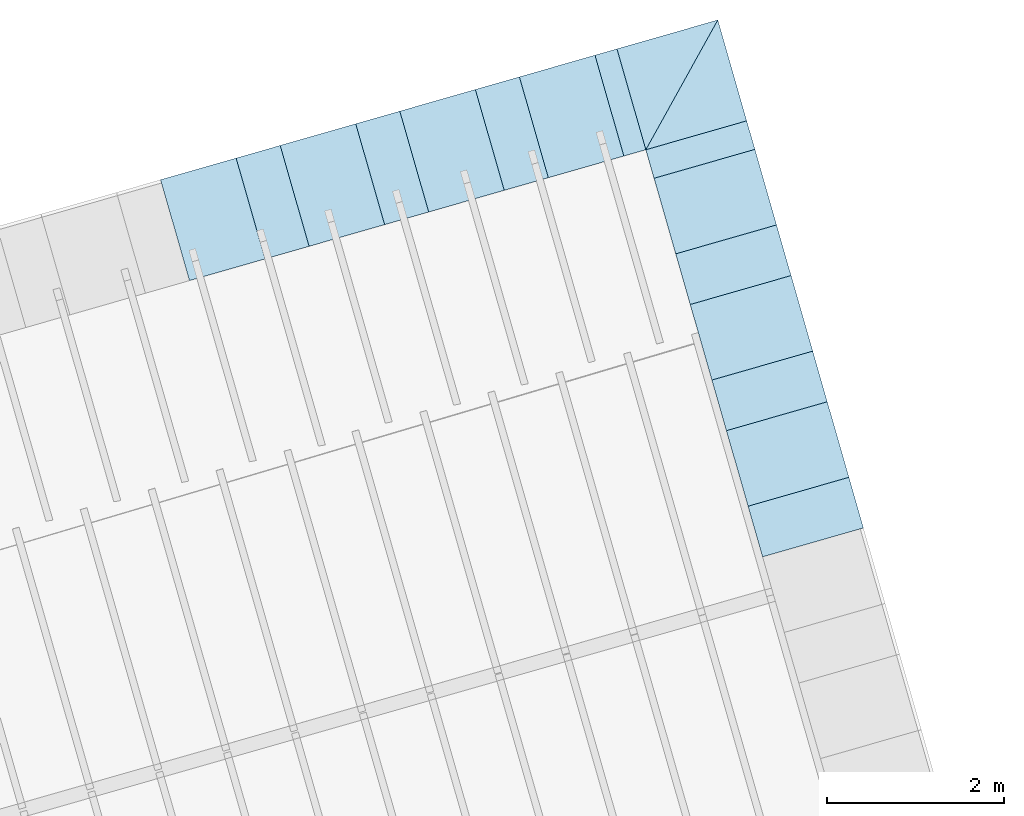
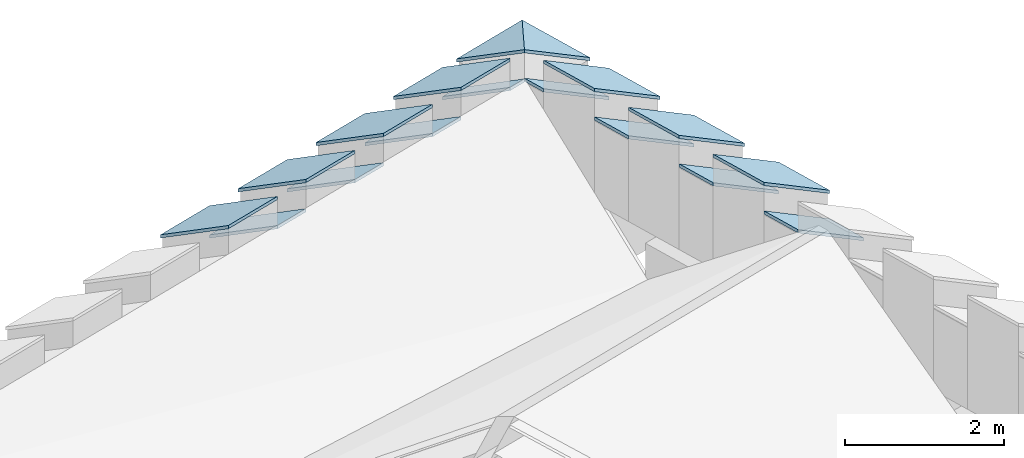
# One storey, part 4 of 10: 17 roofs.
"""IFC4 building model written with IfcOpenShell, lengths in metres."""

from ifc_helpers import new_model, entity, si_unit, converted_unit, derived_unit, direction, frame, origin_with_axes, place, context, subcontext, project, spatial, polygons, material, type_object, element, save


model = new_model("IFC4")

# Units and contexts
model_context = context("Model", 3, precision=1e-05, world=origin_with_axes(), true_north=direction((0.0, 1.0)))
body_context = subcontext(model_context, "Body", "Model", "MODEL_VIEW")
ifc_project = project(units=[si_unit("LENGTHUNIT", "METRE"), si_unit("AREAUNIT", "SQUARE_METRE"), si_unit("VOLUMEUNIT", "CUBIC_METRE"), converted_unit("PLANEANGLEUNIT", "DEGREE", entity("IfcPlaneAngleMeasure", 0.0174532925199433), si_unit("PLANEANGLEUNIT", "RADIAN"), dimensions=[0, 0, 0, 0, 0, 0, 0]), converted_unit("TIMEUNIT", "Year", entity("IfcTimeMeasure", 31557600.0), si_unit("TIMEUNIT", "SECOND"), dimensions=[0, 0, 1, 0, 0, 0, 0]), si_unit("MASSUNIT", "GRAM", prefix="KILO"), si_unit("THERMODYNAMICTEMPERATUREUNIT", "DEGREE_CELSIUS"), si_unit("LUMINOUSINTENSITYUNIT", "LUMEN"), si_unit("ENERGYUNIT", "JOULE", prefix="MEGA"), derived_unit("THERMALCONDUCTANCEUNIT", [(si_unit("POWERUNIT", "WATT"), 1), (si_unit("LENGTHUNIT", "METRE"), -1), (si_unit("THERMODYNAMICTEMPERATUREUNIT", "KELVIN"), -1)]), derived_unit("SPECIFICHEATCAPACITYUNIT", [(si_unit("ENERGYUNIT", "JOULE"), 1), (si_unit("MASSUNIT", "GRAM", prefix="KILO"), -1), (si_unit("THERMODYNAMICTEMPERATUREUNIT", "KELVIN"), -1)]), derived_unit("MASSDENSITYUNIT", [(si_unit("MASSUNIT", "GRAM", prefix="KILO"), 1), (si_unit("VOLUMEUNIT", "CUBIC_METRE"), -1)])], contexts=[model_context])

# Site, building, storey
site_placement = place(None, frame((0.0, 0.0, 0.0), z_axis=(0.0, 0.0, 1.0), x_axis=(0.9612616959383189, 0.2756373558169991, 0.0)))
site = spatial("IfcSite", under=ifc_project, at=site_placement, CompositionType="ELEMENT")
building_placement = place(site_placement, origin_with_axes())
building = spatial("IfcBuilding", under=site, at=building_placement, CompositionType="ELEMENT")
storey_placement = place(building_placement, frame((0.0, 0.0, 11.0), z_axis=(0.0, 0.0, 1.0), x_axis=(1.0, 0.0, 0.0)))
storey = spatial("IfcBuildingStorey", under=building, at=storey_placement, Name="Dach", CompositionType="ELEMENT", Elevation=11.0)

# Roofs
ifc_material = material(Name="schwarz")
roof_type = type_object("IfcRoofType", Name="schwarz 43", PredefinedType="NOTDEFINED")
roof_1_placement = place(storey_placement, frame((31.60143138456926, 13.95742781004919, 1.213699999999999), z_axis=(0.0, 0.0, 1.0), x_axis=(0.0, 1.0, 0.0)))
element("IfcRoof", 1, at=roof_1_placement, inside=storey, type_object=roof_type, material=ifc_material, Name="Dach-060", PredefinedType="NOTDEFINED", context=body_context, shape_type="Tessellation", body=[
    polygons([(0.8900025616952458, -0.03772698703641097, 0.02714466037988217), (0.8900025616952494, 1.149999999999988, 0.7466800857374238), (0.0, 1.149999999999991, 0.7466800857374274), (0.0, -0.03772698703641097, 0.02714466037988217), (0.8900025620847654, -0.03772698691103571, -0.02285533967409492), (0.8900025620847671, 1.150000000333105, 0.6966800858093016), (3.51640494500316e-10, 1.150000000333105, 0.6966800858093016), (3.516387181434766e-10, -0.03772698691103571, -0.02285533967409492)], [[[1, 2, 3, 4]], [[2, 1, 5, 6]], [[3, 2, 6, 7]], [[4, 3, 7, 8]], [[1, 4, 8, 5]], [[6, 5, 8, 7]]], closed=True),
])
roof_2_placement = place(storey_placement, frame((31.60143138441791, 15.4438330749515, 1.213699999999999), z_axis=(0.0, 0.0, 1.0), x_axis=(0.0, 1.0, 0.0)))
element("IfcRoof", 2, at=roof_2_placement, inside=storey, type_object=roof_type, material=ifc_material, Name="Dach-060", PredefinedType="NOTDEFINED", context=body_context, shape_type="Tessellation", body=[
    polygons([(0.8900025616952458, -0.03772698703640742, 0.02714466037987862), (0.8900025616952458, 1.149999999999988, 0.7466800857374238), (0.0, 1.149999999999995, 0.7466800857374274), (0.0, -0.03772698703640742, 0.02714466037987862), (0.8900025620847654, -0.03772698691103571, -0.02285533967409847), (0.8900025620847618, 1.150000000333108, 0.6966800858092981), (3.516369417866372e-10, 1.150000000333108, 0.6966800858092981), (3.516351654297978e-10, -0.03772698691103571, -0.02285533967409847)], [[[1, 2, 3, 4]], [[2, 1, 5, 6]], [[3, 2, 6, 7]], [[4, 3, 7, 8]], [[1, 4, 8, 5]], [[6, 5, 8, 7]]], closed=True),
])
roof_3_placement = place(storey_placement, frame((31.60143138462978, 13.95742672876634, 0.7745999999999995), z_axis=(0.0, 0.0, 1.0), x_axis=(0.0, -1.0, 0.0)))
element("IfcRoof", 3, at=roof_3_placement, inside=storey, type_object=roof_type, material=ifc_material, Name="Dach-059", PredefinedType="NOTDEFINED", context=body_context, shape_type="Tessellation", body=[
    polygons([(0.0, -1.149999999999999, 0.7466800857374274), (0.5964000000000027, -1.149999999999991, 0.7466800857374238), (0.5963999999999992, 0.03772698703645005, 0.02714466037985375), (0.0, 0.03772698703645005, 0.02714466037985375), (-3.895159750300081e-10, -1.150000000333108, 0.6966800858093016), (0.5963999997654561, -1.150000000333108, 0.6966800858093016), (0.5963999997654561, 0.03772698691103216, -0.02285533967409847), (-3.895159750300081e-10, 0.03772698691103216, -0.02285533967409847)], [[[1, 2, 3, 4]], [[2, 1, 5, 6]], [[3, 2, 6, 7]], [[4, 3, 7, 8]], [[1, 4, 8, 5]], [[6, 5, 8, 7]]], closed=True),
])
roof_4_placement = place(storey_placement, frame((31.60143138444817, 15.44383253431008, 0.7745999999999995), z_axis=(0.0, 0.0, 1.0), x_axis=(0.0, -1.0, 0.0)))
element("IfcRoof", 4, at=roof_4_placement, inside=storey, type_object=roof_type, material=ifc_material, Name="Dach-059", PredefinedType="NOTDEFINED", context=body_context, shape_type="Tessellation", body=[
    polygons([(0.0, -1.149999999999995, 0.7466800857374274), (0.5964000000000027, -1.149999999999988, 0.7466800857374238), (0.5963999999999992, 0.03772698703645361, 0.02714466037985375), (0.0, 0.03772698703645361, 0.02714466037985375), (-3.895159750300081e-10, -1.150000000333105, 0.6966800858093016), (0.5963999997654561, -1.150000000333105, 0.6966800858093016), (0.5963999997654561, 0.03772698691103571, -0.02285533967409492), (-3.895159750300081e-10, 0.03772698691103571, -0.02285533967409492)], [[[1, 2, 3, 4]], [[2, 1, 5, 6]], [[3, 2, 6, 7]], [[4, 3, 7, 8]], [[1, 4, 8, 5]], [[6, 5, 8, 7]]], closed=True),
])
roof_5_placement = place(storey_placement, frame((31.60143138426657, 16.93023833985382, 0.7745999999999995), z_axis=(0.0, 0.0, 1.0), x_axis=(0.0, -1.0, 0.0)))
element("IfcRoof", 5, at=roof_5_placement, inside=storey, type_object=roof_type, material=ifc_material, Name="Dach-059", PredefinedType="NOTDEFINED", context=body_context, shape_type="Tessellation", body=[
    polygons([(0.0, -1.149999999999999, 0.7466800857374309), (0.5964000000000027, -1.149999999999988, 0.7466800857374238), (0.5963999999999956, 0.03772698703645361, 0.02714466037985019), (0.0, 0.03772698703645361, 0.02714466037985019), (-3.895159750300081e-10, -1.150000000333112, 0.6966800858093016), (0.5963999997654561, -1.150000000333112, 0.6966800858093016), (0.5963999997654561, 0.0377269869110286, -0.02285533967409492), (-3.895159750300081e-10, 0.0377269869110286, -0.02285533967409492)], [[[1, 2, 3, 4]], [[2, 1, 5, 6]], [[3, 2, 6, 7]], [[4, 3, 7, 8]], [[1, 4, 8, 5]], [[6, 5, 8, 7]]], closed=True),
])
roof_6_placement = place(storey_placement, frame((31.60143139039683, 18.15664638990928, 0.7745999999999995), z_axis=(0.0, 0.0, 1.0), x_axis=(0.0, -1.0, 0.0)))
element("IfcRoof", 6, at=roof_6_placement, inside=storey, type_object=roof_type, material=ifc_material, Name="Dach-058", PredefinedType="NOTDEFINED", context=body_context, shape_type="Tessellation", body=[
    polygons([(-7.37155403385259e-09, 0.03772698688035447, 0.02714466032906415), (2.247008623612601e-07, -1.14999999652429, 0.7466800945752929), (0.3364054846060398, -1.149999993345968, 0.7466800926498394), (0.3364054841255495, 0.03772698688035447, 0.02714466032906415), (-1.210476341384492e-08, 0.03772698706562139, -0.02285534011997115), (2.207258802400247e-07, -1.149999996857442, 0.6966800944403211), (0.3364054846092657, -1.149999993671226, 0.696680092510082), (0.3364054836779431, 0.03772698706562139, -0.02285534011997115)], [[[1, 2, 3, 4]], [[2, 1, 5, 6]], [[3, 2, 6, 7]], [[4, 3, 7, 8]], [[1, 4, 8, 5]], [[6, 5, 8, 7]]], closed=True),
])
roof_7_placement = place(storey_placement, frame((31.60143138426657, 16.93023833985382, 1.213699999999999), z_axis=(0.0, 0.0, 1.0), x_axis=(0.0, 1.0, 0.0)))
element("IfcRoof", 7, at=roof_7_placement, inside=storey, type_object=roof_type, material=ifc_material, Name="Dach-060", PredefinedType="NOTDEFINED", context=body_context, shape_type="Tessellation", body=[
    polygons([(0.8900025616952476, -0.03772698703641097, 0.02714466037987862), (0.8900025616952476, 1.149999999999988, 0.7466800857374238), (0.0, 1.149999999999995, 0.7466800857374274), (0.0, -0.03772698703641097, 0.02714466037987862), (0.8900025620847671, -0.03772698691103571, -0.02285533967409492), (0.8900025620847636, 1.150000000333108, 0.6966800858093016), (3.516369417866372e-10, 1.150000000333108, 0.6966800858093016), (3.51640494500316e-10, -0.03772698691103571, -0.02285533967409492)], [[[1, 2, 3, 4]], [[2, 1, 5, 6]], [[3, 2, 6, 7]], [[4, 3, 7, 8]], [[1, 4, 8, 5]], [[6, 5, 8, 7]]], closed=True),
])
roof_8_placement = place(storey_placement, frame((25.96558752642708, 19.30664615507484, 1.213699999999999), z_axis=(0.0, 0.0, 1.0), x_axis=(-1.0, 0.0, 0.0)))
element("IfcRoof", 8, at=roof_8_placement, inside=storey, type_object=roof_type, material=ifc_material, Name="Dach-057", PredefinedType="NOTDEFINED", context=body_context, shape_type="Tessellation", body=[
    polygons([(0.8900025616952547, -0.0377269870364465, 0.0271446603798573), (0.8900025616952547, 1.149999999999995, 0.7466800857374327), (0.0, 1.149999999999995, 0.7466800857374327), (0.0, -0.0377269870364465, 0.0271446603798573), (0.8900025620847707, -0.03772698691103926, -0.02285533967409847), (0.8900025620847707, 1.150000000333101, 0.6966800858093016), (3.516440472139948e-10, 1.150000000333101, 0.6966800858093016), (3.516440472139948e-10, -0.03772698691103926, -0.02285533967409847)], [[[1, 2, 3, 4]], [[2, 1, 5, 6]], [[3, 2, 6, 7]], [[4, 3, 7, 8]], [[1, 4, 8, 5]], [[6, 5, 8, 7]]], closed=True),
])
roof_9_placement = place(storey_placement, frame((27.37454827656133, 19.3066461584527, 1.213699999999999), z_axis=(0.0, 0.0, 1.0), x_axis=(-1.0, 0.0, 0.0)))
element("IfcRoof", 9, at=roof_9_placement, inside=storey, type_object=roof_type, material=ifc_material, Name="Dach-057", PredefinedType="NOTDEFINED", context=body_context, shape_type="Tessellation", body=[
    polygons([(0.8900025616952547, -0.0377269870364465, 0.02714466037985552), (0.8900025616952547, 1.149999999999999, 0.7466800857374327), (0.0, 1.149999999999999, 0.7466800857374327), (0.0, -0.0377269870364465, 0.02714466037985552), (0.8900025620847707, -0.03772698691103571, -0.02285533967409847), (0.8900025620847707, 1.150000000333101, 0.6966800858093016), (3.516440472139948e-10, 1.150000000333101, 0.6966800858093016), (3.516440472139948e-10, -0.03772698691103571, -0.02285533967409847)], [[[1, 2, 3, 4]], [[2, 1, 5, 6]], [[3, 2, 6, 7]], [[4, 3, 7, 8]], [[1, 4, 8, 5]], [[6, 5, 8, 7]]], closed=True),
])
roof_10_placement = place(storey_placement, frame((28.7835090266956, 19.30664616183056, 1.213699999999999), z_axis=(0.0, 0.0, 1.0), x_axis=(-1.0, 0.0, 0.0)))
element("IfcRoof", 10, at=roof_10_placement, inside=storey, type_object=roof_type, material=ifc_material, Name="Dach-057", PredefinedType="NOTDEFINED", context=body_context, shape_type="Tessellation", body=[
    polygons([(0.8900025616952547, -0.03772698703645005, 0.02714466037985197), (0.8900025616952547, 1.149999999999999, 0.7466800857374327), (0.0, 1.149999999999999, 0.7466800857374327), (0.0, -0.03772698703644295, 0.0271446603798573), (0.8900025620847707, -0.03772698691103571, -0.02285533967409847), (0.8900025620847707, 1.150000000333105, 0.6966800858093034), (3.516440472139948e-10, 1.150000000333105, 0.6966800858093034), (3.516440472139948e-10, -0.03772698691103571, -0.02285533967409847)], [[[1, 2, 3, 4]], [[2, 1, 5, 6]], [[3, 2, 6, 7]], [[4, 3, 7, 8]], [[1, 4, 8, 5]], [[6, 5, 8, 7]]], closed=True),
])
roof_11_placement = place(storey_placement, frame((30.19246977682985, 19.30664616520842, 1.213699999999999), z_axis=(0.0, 0.0, 1.0), x_axis=(-1.0, 0.0, 0.0)))
element("IfcRoof", 11, at=roof_11_placement, inside=storey, type_object=roof_type, material=ifc_material, Name="Dach-057", PredefinedType="NOTDEFINED", context=body_context, shape_type="Tessellation", body=[
    polygons([(0.8900025616952547, -0.03772698703645005, 0.02714466037985197), (0.8900025616952547, 1.149999999999999, 0.7466800857374309), (0.0, 1.149999999999999, 0.7466800857374309), (0.0, -0.03772698703644295, 0.02714466037985552), (0.8900025620847707, -0.03772698691103216, -0.02285533967409847), (0.8900025620847707, 1.150000000333105, 0.6966800858093016), (3.516440472139948e-10, 1.150000000333105, 0.6966800858093016), (3.516440472139948e-10, -0.03772698691103216, -0.02285533967409847)], [[[1, 2, 3, 4]], [[2, 1, 5, 6]], [[3, 2, 6, 7]], [[4, 3, 7, 8]], [[1, 4, 8, 5]], [[6, 5, 8, 7]]], closed=True),
])
roof_12_placement = place(storey_placement, frame((30.45143138835296, 19.30664616645134, 1.213699411030737), z_axis=(0.0, 0.0, 1.0), x_axis=(1.0, 0.0, 0.0)))
element("IfcRoof", 12, at=roof_12_placement, inside=storey, type_object=roof_type, material=ifc_material, Name="Dach-052", PredefinedType="NOTDEFINED", context=body_context, shape_type="Tessellation", body=[
    polygons([(-1.026982943130861e-10, 0.03772756924567844, 0.02714484985551557), (3.130345760382625e-09, -1.150000000000002, 0.7466392679194129), (1.187727569143259, 0.03772756924572107, 0.02714484985548893), (-5.617089016141108e-10, 0.03772756941491906, -0.02285437878040675), (3.163581396847803e-09, -1.150000000395778, 0.6966400396257644), (1.187727569103348, 0.03772756941491906, -0.02285437878040675)], [[[1, 2, 3]], [[2, 1, 4, 5]], [[3, 2, 5, 6]], [[1, 3, 6, 4]], [[5, 4, 6]]], closed=True),
])
roof_13_placement = place(storey_placement, frame((31.601431388353, 18.15664616645138, 1.213699411030737), z_axis=(0.0, 0.0, 1.0), x_axis=(0.0, 1.0, 0.0)))
element("IfcRoof", 13, at=roof_13_placement, inside=storey, type_object=roof_type, material=ifc_material, Name="Dach-051", PredefinedType="NOTDEFINED", context=body_context, shape_type="Tessellation", body=[
    polygons([(1.187727569245936, -0.0377275691432466, 0.02714484989189181), (-1.990088094316889e-10, 1.149999997068683, 0.7466392680765228), (-1.990372311411193e-10, -0.03772756914321818, 0.02714484989190957), (1.187727569634127, -0.03772756908859165, -0.02285437864493112), (0.0, 1.149999997400538, 0.6966400397076189), (0.0, -0.03772756908859165, -0.02285437864493112)], [[[1, 2, 3]], [[2, 1, 4, 5]], [[3, 2, 5, 6]], [[1, 3, 6, 4]], [[5, 4, 6]]], closed=True),
])
roof_14_placement = place(storey_placement, frame((29.30246799160692, 19.28865916795364, 0.7745999999999995), z_axis=(0.0, 0.0, 1.0), x_axis=(-1.0, 0.0, 0.0)))
element("IfcRoof", 14, at=roof_14_placement, inside=storey, type_object=roof_type, material=ifc_material, Name="Dach-048", PredefinedType="NOTDEFINED", context=body_context, shape_type="Tessellation", body=[
    polygons([(0.5189582746531372, -0.05571398314985387, 0.01624798038468356), (0.51895827465313, 1.132013003886581, 0.7357834057422572), (0.0, 1.132013003886581, 0.7357834057422572), (0.0, -0.05571398314986453, 0.01624798038467823), (0.5189582750426531, -0.05571398302445019, -0.03375201966927399), (0.5189582750426531, 1.132013004219687, 0.6857834058141261), (-1.637339153148787e-10, 1.132013004219687, 0.6857834058141261), (-1.637339153148787e-10, -0.05571398302445019, -0.03375201966927399)], [[[1, 2, 3, 4]], [[2, 1, 5, 6]], [[3, 2, 6, 7]], [[4, 3, 7, 8]], [[1, 4, 8, 5]], [[6, 5, 8, 7]]], closed=True),
])
roof_15_placement = place(storey_placement, frame((26.48454515990777, 19.28865916076228, 0.7745999999999995), z_axis=(0.0, 0.0, 1.0), x_axis=(-1.0, 0.0, 0.0)))
element("IfcRoof", 15, at=roof_15_placement, inside=storey, type_object=roof_type, material=ifc_material, Name="Dach-048", PredefinedType="NOTDEFINED", context=body_context, shape_type="Tessellation", body=[
    polygons([(0.5189582746531372, -0.05571398314985743, 0.01624798038468178), (0.51895827465313, 1.132013003886584, 0.7357834057422572), (0.0, 1.132013003886584, 0.7357834057422572), (0.0, -0.05571398314985743, 0.01624798038468178), (0.5189582750426531, -0.05571398302445019, -0.03375201966927399), (0.5189582750426531, 1.13201300421969, 0.6857834058141279), (-1.637339153148787e-10, 1.13201300421969, 0.6857834058141279), (-1.637339153148787e-10, -0.05571398302445019, -0.03375201966927399)], [[[1, 2, 3, 4]], [[2, 1, 5, 6]], [[3, 2, 6, 7]], [[4, 3, 7, 8]], [[1, 4, 8, 5]], [[6, 5, 8, 7]]], closed=True),
])
roof_16_placement = place(storey_placement, frame((27.89350657575734, 19.28865916435796, 0.7745999999999995), z_axis=(0.0, 0.0, 1.0), x_axis=(-1.0, 0.0, 0.0)))
element("IfcRoof", 16, at=roof_16_placement, inside=storey, type_object=roof_type, material=ifc_material, Name="Dach-048", PredefinedType="NOTDEFINED", context=body_context, shape_type="Tessellation", body=[
    polygons([(0.5189582746531372, -0.05571398314985743, 0.01624798038468001), (0.51895827465313, 1.132013003886584, 0.7357834057422554), (0.0, 1.132013003886584, 0.7357834057422554), (0.0, -0.05571398314985743, 0.01624798038468001), (0.5189582750426531, -0.05571398302445019, -0.03375201966927577), (0.5189582750426531, 1.13201300421969, 0.6857834058141261), (-1.637339153148787e-10, 1.13201300421969, 0.6857834058141261), (-1.637339153148787e-10, -0.05571398302445019, -0.03375201966927577)], [[[1, 2, 3, 4]], [[2, 1, 5, 6]], [[3, 2, 6, 7]], [[4, 3, 7, 8]], [[1, 4, 8, 5]], [[6, 5, 8, 7]]], closed=True),
])
roof_17_placement = place(storey_placement, frame((30.45143139387253, 19.28865916909501, 0.7745999999999995), z_axis=(0.0, 0.0, 1.0), x_axis=(-1.0, 0.0, 0.0)))
element("IfcRoof", 17, at=roof_17_placement, inside=storey, type_object=roof_type, material=ifc_material, Name="Dach-048", PredefinedType="NOTDEFINED", context=body_context, shape_type="Tessellation", body=[
    polygons([(0.2589616170426829, -0.05571398314985743, 0.01624798038467823), (0.2589616170427114, 1.132013003886584, 0.7357834057422536), (0.0, 1.132013003886595, 0.7357834057422608), (0.0, -0.05571398314985032, 0.01624798038468178), (0.2589616174322273, -0.05571398302443953, -0.03375201966927222), (0.2589616174322309, 1.132013004219701, 0.6857834058141297), (4.169287137756328e-10, 1.132013004219701, 0.6857834058141297), (4.16925161061954e-10, -0.05571398302443953, -0.03375201966927222)], [[[1, 2, 3, 4]], [[2, 1, 5, 6]], [[3, 2, 6, 7]], [[4, 3, 7, 8]], [[1, 4, 8, 5]], [[6, 5, 8, 7]]], closed=True),
])

save(model, "model.ifc")
